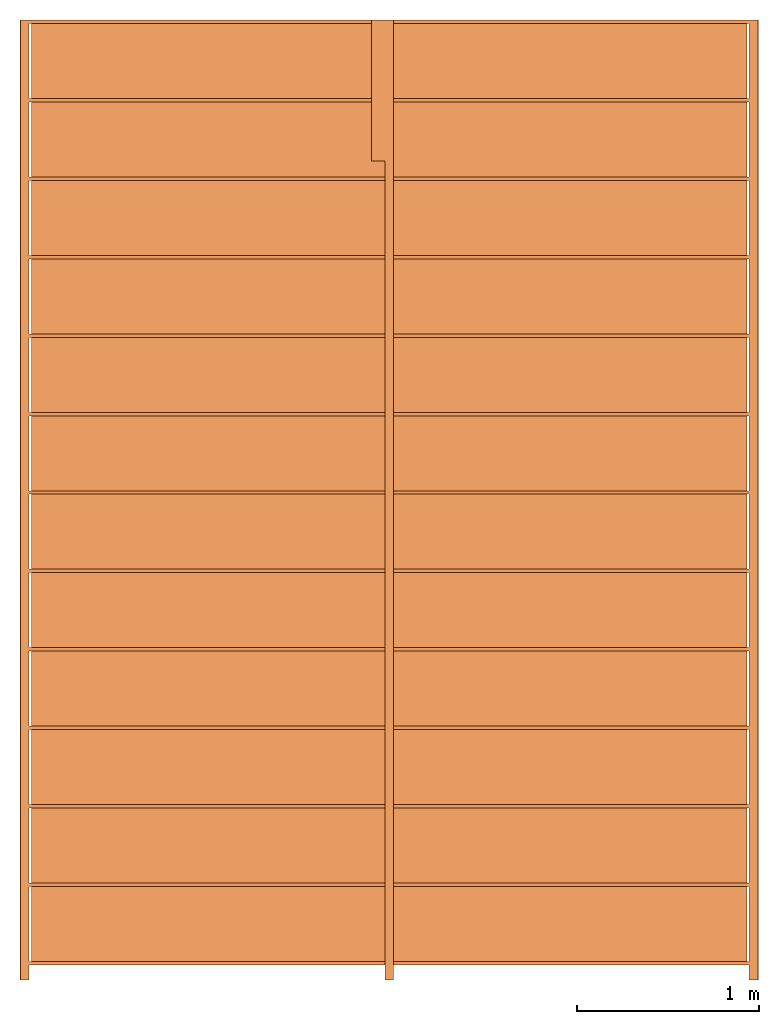
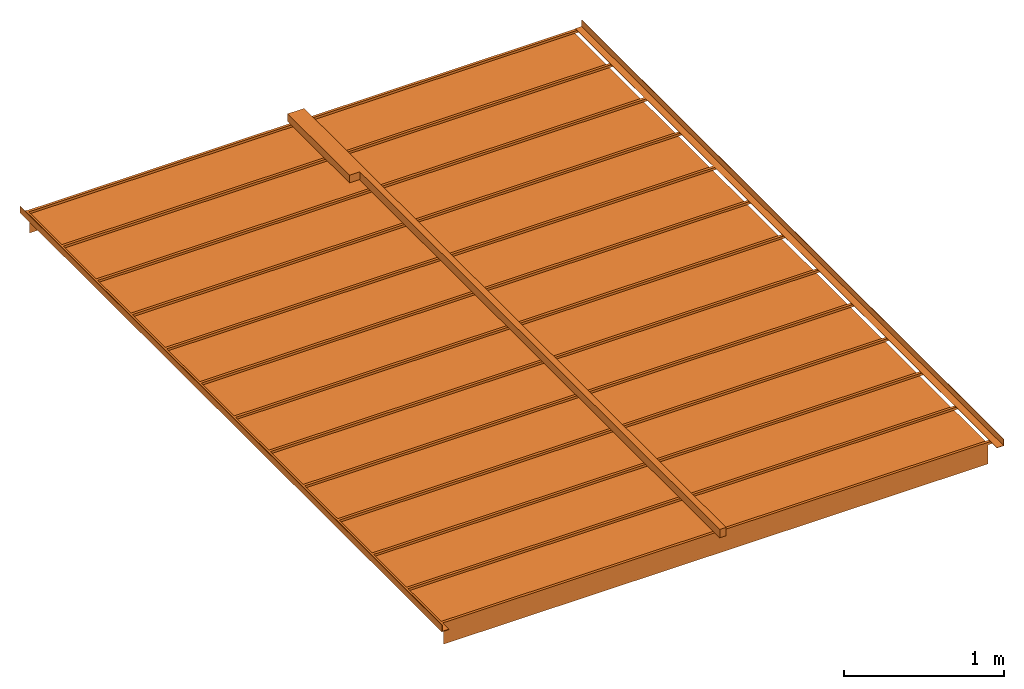
# One storey: 1 proxy.
"""IFC2X3 building model written with IfcOpenShell, lengths in feet."""

from ifc_helpers import new_model, entity, si_unit, converted_unit, derived_unit, direction, frame, frame_2d, origin, origin_2d_with_axis, place, context, subcontext, project, spatial, polyline, rectangle, outline, extrude, source, transform, mapped, material, material_list, type_object, type_shapes, element, save


model = new_model("IFC2X3")

# Units and contexts
model_context = context("Model", 3, precision=0.0001, world=origin(), true_north=direction((6.123031769111886e-17, 1.0)))
plan_context = context("Plan", 3, precision=0.0001, world=origin(), true_north=direction((6.123031769111886e-17, 1.0)))
body_context = subcontext(model_context, "Body", "Model", "MODEL_VIEW")
ifc_project = project(units=[converted_unit("LENGTHUNIT", "FOOT", entity("IfcRatioMeasure", 0.3048), si_unit("LENGTHUNIT", "METRE"), dimensions=[1, 0, 0, 0, 0, 0, 0]), converted_unit("AREAUNIT", "SQUARE FOOT", entity("IfcRatioMeasure", 0.09290304), si_unit("AREAUNIT", "SQUARE_METRE"), dimensions=[2, 0, 0, 0, 0, 0, 0]), converted_unit("VOLUMEUNIT", "CUBIC FOOT", entity("IfcRatioMeasure", 0.028316846592000004), si_unit("VOLUMEUNIT", "CUBIC_METRE"), dimensions=[3, 0, 0, 0, 0, 0, 0]), converted_unit("PLANEANGLEUNIT", "DEGREE", entity("IfcRatioMeasure", 0.017453292519943278), si_unit("PLANEANGLEUNIT", "RADIAN"), dimensions=[0, 0, 0, 0, 0, 0, 0]), si_unit("MASSUNIT", "GRAM", prefix="KILO"), derived_unit("MASSDENSITYUNIT", [(si_unit("MASSUNIT", "GRAM", prefix="KILO"), 1), (si_unit("LENGTHUNIT", "METRE"), -3)]), derived_unit("MOMENTOFINERTIAUNIT", [(si_unit("LENGTHUNIT", "METRE"), 4)]), si_unit("TIMEUNIT", "SECOND"), si_unit("FREQUENCYUNIT", "HERTZ"), si_unit("THERMODYNAMICTEMPERATUREUNIT", "DEGREE_CELSIUS"), derived_unit("THERMALTRANSMITTANCEUNIT", [(si_unit("MASSUNIT", "GRAM", prefix="KILO"), 1), (si_unit("THERMODYNAMICTEMPERATUREUNIT", "KELVIN"), -1), (si_unit("TIMEUNIT", "SECOND"), -3)]), derived_unit("VOLUMETRICFLOWRATEUNIT", [(si_unit("LENGTHUNIT", "METRE"), 3), (si_unit("TIMEUNIT", "SECOND"), -1)]), derived_unit("MASSFLOWRATEUNIT", [(si_unit("MASSUNIT", "GRAM", prefix="KILO"), 1), (si_unit("TIMEUNIT", "SECOND"), -1)]), derived_unit("ROTATIONALFREQUENCYUNIT", [(si_unit("TIMEUNIT", "SECOND"), -1)]), si_unit("ELECTRICCURRENTUNIT", "AMPERE"), si_unit("ELECTRICVOLTAGEUNIT", "VOLT"), si_unit("POWERUNIT", "WATT"), si_unit("FORCEUNIT", "NEWTON"), si_unit("ILLUMINANCEUNIT", "LUX"), si_unit("LUMINOUSFLUXUNIT", "LUMEN"), si_unit("LUMINOUSINTENSITYUNIT", "CANDELA"), derived_unit("USERDEFINED", [(si_unit("MASSUNIT", "GRAM", prefix="KILO"), -1), (si_unit("LENGTHUNIT", "METRE"), -2), (si_unit("TIMEUNIT", "SECOND"), 3), (si_unit("LUMINOUSFLUXUNIT", "LUMEN"), 1)]), derived_unit("SOUNDPOWERUNIT", [(si_unit("MASSUNIT", "GRAM", prefix="KILO"), 1), (si_unit("LENGTHUNIT", "METRE"), 2), (si_unit("TIMEUNIT", "SECOND"), -3)]), derived_unit("LINEARVELOCITYUNIT", [(si_unit("LENGTHUNIT", "METRE"), 1), (si_unit("TIMEUNIT", "SECOND"), -1)]), si_unit("PRESSUREUNIT", "PASCAL"), derived_unit("USERDEFINED", [(si_unit("LENGTHUNIT", "METRE"), -2), (si_unit("MASSUNIT", "GRAM", prefix="KILO"), 1), (si_unit("TIMEUNIT", "SECOND"), -2)]), derived_unit("LINEARFORCEUNIT", [(si_unit("MASSUNIT", "GRAM", prefix="KILO"), 1), (si_unit("LENGTHUNIT", "METRE"), 1), (si_unit("TIMEUNIT", "SECOND"), -2), (si_unit("LENGTHUNIT", "METRE"), -1)]), derived_unit("PLANARFORCEUNIT", [(si_unit("MASSUNIT", "GRAM", prefix="KILO"), 1), (si_unit("LENGTHUNIT", "METRE"), 1), (si_unit("TIMEUNIT", "SECOND"), -2), (si_unit("LENGTHUNIT", "METRE"), -2)])], contexts=[model_context, plan_context])

# Site, building, storey
site_placement = place(None, origin())
site = spatial("IfcSite", under=ifc_project, at=site_placement, CompositionType="ELEMENT")
building_placement = place(site_placement, origin())
building = spatial("IfcBuilding", under=site, at=building_placement, CompositionType="ELEMENT")
storey_placement = place(building_placement, origin())
storey = spatial("IfcBuildingStorey", under=building, at=storey_placement, Name="Level 1", CompositionType="ELEMENT", Elevation=0.0)

# Proxy
ifc_material_1 = material()
ifc_material_2 = material()
ifc_material_list_1 = material_list([ifc_material_1, ifc_material_2, ifc_material_1, ifc_material_2, ifc_material_1, ifc_material_2, ifc_material_1, ifc_material_2, ifc_material_1, ifc_material_2, ifc_material_1, ifc_material_2, ifc_material_1, ifc_material_2, ifc_material_1, ifc_material_2, ifc_material_1, ifc_material_2, ifc_material_1, ifc_material_2, ifc_material_1, ifc_material_2, ifc_material_1, ifc_material_2, ifc_material_2, ifc_material_2, ifc_material_1, ifc_material_1, ifc_material_1, ifc_material_1, ifc_material_1])
ifc_material_list_2 = material_list([ifc_material_1, ifc_material_2, ifc_material_1, ifc_material_2, ifc_material_1, ifc_material_2, ifc_material_1, ifc_material_2, ifc_material_1, ifc_material_2, ifc_material_1, ifc_material_2, ifc_material_1, ifc_material_2, ifc_material_1, ifc_material_2, ifc_material_1, ifc_material_2, ifc_material_1, ifc_material_2, ifc_material_1, ifc_material_2, ifc_material_1, ifc_material_2, ifc_material_2, ifc_material_2, ifc_material_1, ifc_material_1, ifc_material_1, ifc_material_1, ifc_material_1])
building_element_proxy_type = type_object("IfcBuildingElementProxyType", PredefinedType="NOTDEFINED", material=ifc_material_list_2)
shared_shape = source(origin(), body_context, "Body", "SweptSolid", [
    extrude(rectangle(XDim=13.166666666666671, YDim=0.062499999999973355, at=frame_2d((0.0, 8.881784197001252e-16), x_axis=(1.0, 0.0))), frame((0.73723035330947, -11.94791666666761, 9.427083333333325), z_axis=(0.0, 0.0, 1.0), x_axis=(-1.0, 0.0, 0.0)), (0.0, 0.0, 1.0), 0.0625),
    extrude(rectangle(XDim=1.3541666666666679, YDim=12.91666666666666, at=frame_2d((0.0, 4.440892098500626e-16), x_axis=(1.0, 0.0))), frame((0.7372303533094671, -11.239583333334304, 9.427083333333332), z_axis=(0.0, 0.0, 1.0), x_axis=(0.0, 1.0, 0.0)), (0.0, 0.0, 1.0), 0.0052083333333339255),
    extrude(rectangle(XDim=13.166666666666671, YDim=0.062499999999973355, at=frame_2d((0.0, -8.881784197001252e-16), x_axis=(1.0, 0.0))), frame((0.73723035330947, -10.531250000000943, 9.427083333333325), z_axis=(0.0, 0.0, 1.0), x_axis=(-1.0, 0.0, 0.0)), (0.0, 0.0, 1.0), 0.0625),
    extrude(rectangle(XDim=1.3541666666666679, YDim=12.91666666666666, at=frame_2d((0.0, 4.440892098500626e-16), x_axis=(1.0, 0.0))), frame((0.7372303533094671, -9.82291666666764, 9.427083333333332), z_axis=(0.0, 0.0, 1.0), x_axis=(0.0, 1.0, 0.0)), (0.0, 0.0, 1.0), 0.0052083333333339255),
    extrude(rectangle(XDim=13.166666666666671, YDim=0.062499999999973355, at=frame_2d((0.0, -8.881784197001252e-16), x_axis=(1.0, 0.0))), frame((0.73723035330947, -9.114583333334279, 9.427083333333325), z_axis=(0.0, 0.0, 1.0), x_axis=(-1.0, 0.0, 0.0)), (0.0, 0.0, 1.0), 0.0625),
    extrude(rectangle(XDim=1.354166666666667, YDim=12.91666666666666, at=frame_2d((-4.440892098500626e-16, 4.440892098500626e-16), x_axis=(1.0, 0.0))), frame((0.7372303533094671, -8.406250000000973, 9.427083333333332), z_axis=(0.0, 0.0, 1.0), x_axis=(0.0, 1.0, 0.0)), (0.0, 0.0, 1.0), 0.0052083333333339255),
    extrude(rectangle(XDim=13.166666666666671, YDim=0.062499999999973355, at=origin_2d_with_axis()), frame((0.73723035330947, -7.697916666667613, 9.427083333333325), z_axis=(0.0, 0.0, 1.0), x_axis=(-1.0, 0.0, 0.0)), (0.0, 0.0, 1.0), 0.0625),
    extrude(rectangle(XDim=1.354166666666667, YDim=12.91666666666666, at=frame_2d((-4.440892098500626e-16, 4.440892098500626e-16), x_axis=(1.0, 0.0))), frame((0.7372303533094671, -6.989583333334307, 9.427083333333332), z_axis=(0.0, 0.0, 1.0), x_axis=(0.0, 1.0, 0.0)), (0.0, 0.0, 1.0), 0.0052083333333339255),
    extrude(rectangle(XDim=13.166666666666671, YDim=0.062499999999973355, at=origin_2d_with_axis()), frame((0.73723035330947, -6.281250000000947, 9.427083333333325), z_axis=(0.0, 0.0, 1.0), x_axis=(-1.0, 0.0, 0.0)), (0.0, 0.0, 1.0), 0.0625),
    extrude(rectangle(XDim=1.354166666666667, YDim=12.91666666666666, at=frame_2d((-4.440892098500626e-16, 4.440892098500626e-16), x_axis=(1.0, 0.0))), frame((0.7372303533094671, -5.572916666667641, 9.427083333333332), z_axis=(0.0, 0.0, 1.0), x_axis=(0.0, 1.0, 0.0)), (0.0, 0.0, 1.0), 0.0052083333333339255),
    extrude(rectangle(XDim=13.166666666666671, YDim=0.062499999999973355, at=origin_2d_with_axis()), frame((0.73723035330947, -4.8645833333342825, 9.427083333333325), z_axis=(0.0, 0.0, 1.0), x_axis=(-1.0, 0.0, 0.0)), (0.0, 0.0, 1.0), 0.0625),
    extrude(rectangle(XDim=1.354166666666667, YDim=12.91666666666666, at=frame_2d((4.440892098500626e-16, 4.440892098500626e-16), x_axis=(1.0, 0.0))), frame((0.7372303533094671, -4.156250000000977, 9.427083333333332), z_axis=(0.0, 0.0, 1.0), x_axis=(0.0, 1.0, 0.0)), (0.0, 0.0, 1.0), 0.0052083333333339255),
    extrude(rectangle(XDim=13.166666666666671, YDim=0.062499999999973355, at=origin_2d_with_axis()), frame((0.73723035330947, -3.4479166666676164, 9.427083333333325), z_axis=(0.0, 0.0, 1.0), x_axis=(-1.0, 0.0, 0.0)), (0.0, 0.0, 1.0), 0.0625),
    extrude(rectangle(XDim=1.354166666666667, YDim=12.91666666666666, at=frame_2d((0.0, 4.440892098500626e-16), x_axis=(1.0, 0.0))), frame((0.7372303533094671, -2.7395833333343114, 9.427083333333332), z_axis=(0.0, 0.0, 1.0), x_axis=(0.0, 1.0, 0.0)), (0.0, 0.0, 1.0), 0.0052083333333339255),
    extrude(rectangle(XDim=13.166666666666671, YDim=0.062499999999973355, at=origin_2d_with_axis()), frame((0.73723035330947, -2.0312500000009512, 9.427083333333325), z_axis=(0.0, 0.0, 1.0), x_axis=(-1.0, 0.0, 0.0)), (0.0, 0.0, 1.0), 0.0625),
    extrude(rectangle(XDim=1.354166666666667, YDim=12.91666666666666, at=frame_2d((0.0, 4.440892098500626e-16), x_axis=(1.0, 0.0))), frame((0.7372303533094671, -1.3229166666676453, 9.427083333333332), z_axis=(0.0, 0.0, 1.0), x_axis=(0.0, 1.0, 0.0)), (0.0, 0.0, 1.0), 0.0052083333333339255),
    extrude(rectangle(XDim=13.166666666666671, YDim=0.062499999999973355, at=origin_2d_with_axis()), frame((0.73723035330947, -0.6145833333342847, 9.427083333333325), z_axis=(0.0, 0.0, 1.0), x_axis=(-1.0, 0.0, 0.0)), (0.0, 0.0, 1.0), 0.0625),
    extrude(rectangle(XDim=1.3541666666666672, YDim=12.91666666666666, at=frame_2d((0.0, 4.440892098500626e-16), x_axis=(1.0, 0.0))), frame((0.7372303533094671, 0.09374999999902067, 9.427083333333332), z_axis=(0.0, 0.0, 1.0), x_axis=(0.0, 1.0, 0.0)), (0.0, 0.0, 1.0), 0.0052083333333339255),
    extrude(rectangle(XDim=13.166666666666671, YDim=0.062499999999973355, at=origin_2d_with_axis()), frame((0.73723035330947, 0.8020833333323791, 9.427083333333325), z_axis=(0.0, 0.0, 1.0), x_axis=(-1.0, 0.0, 0.0)), (0.0, 0.0, 1.0), 0.0625),
    extrude(rectangle(XDim=1.3541666666666672, YDim=12.91666666666666, at=frame_2d((1.1102230246251565e-16, 4.440892098500626e-16), x_axis=(1.0, 0.0))), frame((0.7372303533094671, 1.5104166666656844, 9.427083333333332), z_axis=(0.0, 0.0, 1.0), x_axis=(0.0, 1.0, 0.0)), (0.0, 0.0, 1.0), 0.0052083333333339255),
    extrude(rectangle(XDim=13.166666666666671, YDim=0.062499999999973355, at=frame_2d((0.0, -8.881784197001252e-16), x_axis=(1.0, 0.0))), frame((0.7372303533094406, -13.364583333334279, 9.427083333333325), z_axis=(0.0, 0.0, 1.0), x_axis=(-1.0, 0.0, 0.0)), (0.0, 0.0, 1.0), 0.0625),
    extrude(rectangle(XDim=1.3541666666666679, YDim=12.91666666666666, at=frame_2d((1.7763568394002505e-15, 0.0), x_axis=(1.0, 0.0))), frame((0.7372303533094371, -12.656250000000973, 9.427083333333332), z_axis=(0.0, 0.0, 1.0), x_axis=(0.0, 1.0, 0.0)), (0.0, 0.0, 1.0), 0.0052083333333339255),
    extrude(rectangle(XDim=13.166666666666671, YDim=0.062499999999973355, at=origin_2d_with_axis()), frame((0.7372303533094708, 2.218749999999045, 9.427083333333325), z_axis=(0.0, 0.0, 1.0), x_axis=(-1.0, 0.0, 0.0)), (0.0, 0.0, 1.0), 0.0625),
    extrude(rectangle(XDim=1.354166666666667, YDim=12.91666666666666, at=origin_2d_with_axis()), frame((0.7372303533094677, 2.927083333332351, 9.427083333333332), z_axis=(0.0, 0.0, 1.0), x_axis=(0.0, 1.0, 0.0)), (0.0, 0.0, 1.0), 0.0052083333333339255),
    extrude(rectangle(XDim=12.91666666666626, YDim=0.005208333333335702, at=origin_2d_with_axis()), frame((0.7372303533092559, -13.367187500000892, 8.927083333333341), z_axis=(0.0, 0.0, 1.0), x_axis=(-1.0, 0.0, 0.0)), (0.0, 0.0, 1.0), 0.5000000000000018),
    extrude(rectangle(XDim=12.91666666666626, YDim=0.005208333333331261, at=frame_2d((0.0, 4.440892098500626e-16), x_axis=(1.0, 0.0))), frame((0.7372303533092852, 3.6365277777768257, 8.92708333333334), z_axis=(0.0, 0.0, 1.0), x_axis=(-1.0, 0.0, 0.0)), (0.0, 0.0, 1.0), 0.5000000000000018),
    extrude(rectangle(XDim=13.166666666666632, YDim=0.06250000000000266, at=origin_2d_with_axis()), frame((0.7372303533092843, 3.635416666665681, 9.427083333333341), z_axis=(0.0, 0.0, 1.0), x_axis=(-1.0, 0.0, 0.0)), (0.0, 0.0, 1.0), 0.06250000000000533),
    extrude(outline(polyline([(-0.10763888888888751, -0.059027777777750146), (0.05902777777777857, -0.059027777777750146), (0.05902777777777857, 0.10763888888891593), (0.048611111111111605, 0.10763888888891593), (0.048611111111111605, -0.04861111111116401), (-0.10763888888888751, -0.04861111111116401), (-0.10763888888888751, -0.059027777777750146)])), frame((-5.870408535579682, -13.66666666666764, 9.5486111111111), z_axis=(0.0, 1.0, 0.0), x_axis=(-1.0, 0.0, 0.0)), (0.0, 0.0, 1.0), 17.33333333333333),
    extrude(outline(polyline([(-0.10763888888888928, -0.04861111111116401), (-0.10763888888888928, -0.059027777777750146), (0.05902777777777857, -0.059027777777750146), (0.05902777777777857, 0.10763888888891593), (0.048611111111110716, 0.10763888888891593), (0.048611111111110716, -0.04861111111116401), (-0.10763888888888928, -0.04861111111116401)])), frame((7.344869242198097, -13.66666666666764, 9.5486111111111), z_axis=(0.0, -1.0, 0.0), x_axis=(1.0, 0.0, 0.0)), (0.0, 0.0, -1.0), 17.33333333333333),
    extrude(rectangle(XDim=2.5416666666667425, YDim=0.24416666666666664, at=origin_2d_with_axis()), frame((0.540980353309244, 2.3958333333321677, 9.55833333333331), z_axis=(0.0, 0.0, 1.0), x_axis=(0.0, 1.0, 0.0)), (0.0, 0.0, 1.0), 0.19166666666666643),
    extrude(rectangle(XDim=17.33333333333333, YDim=0.14833333333315402, at=origin_2d_with_axis()), frame((0.7372303533091928, -5.0, 9.539999999999125), z_axis=(0.0, 0.0, 1.0), x_axis=(0.0, 1.0, 0.0)), (0.0, 0.0, 1.0), 0.2099999999999973),
])
type_shapes(building_element_proxy_type, [shared_shape])
proxy_placement = place(storey_placement, frame((-0.7372303533091928, -4.0, 0.0)))
element("IfcBuildingElementProxy", 1, at=proxy_placement, inside=storey, type_object=building_element_proxy_type, material=ifc_material_list_1, context=body_context, shape_type="MappedRepresentation", body=[
    mapped(shared_shape, transform((0.0, 0.0, 0.0), scale=1.0)),
])

save(model, "model.ifc")
